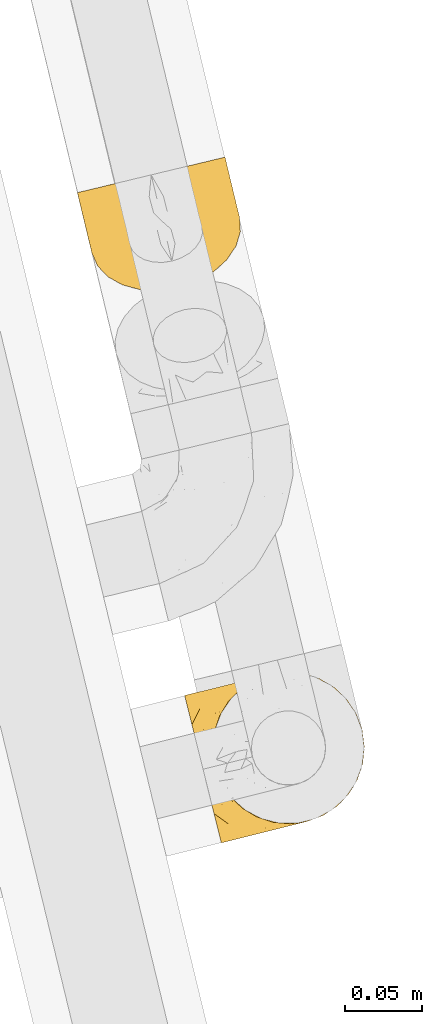
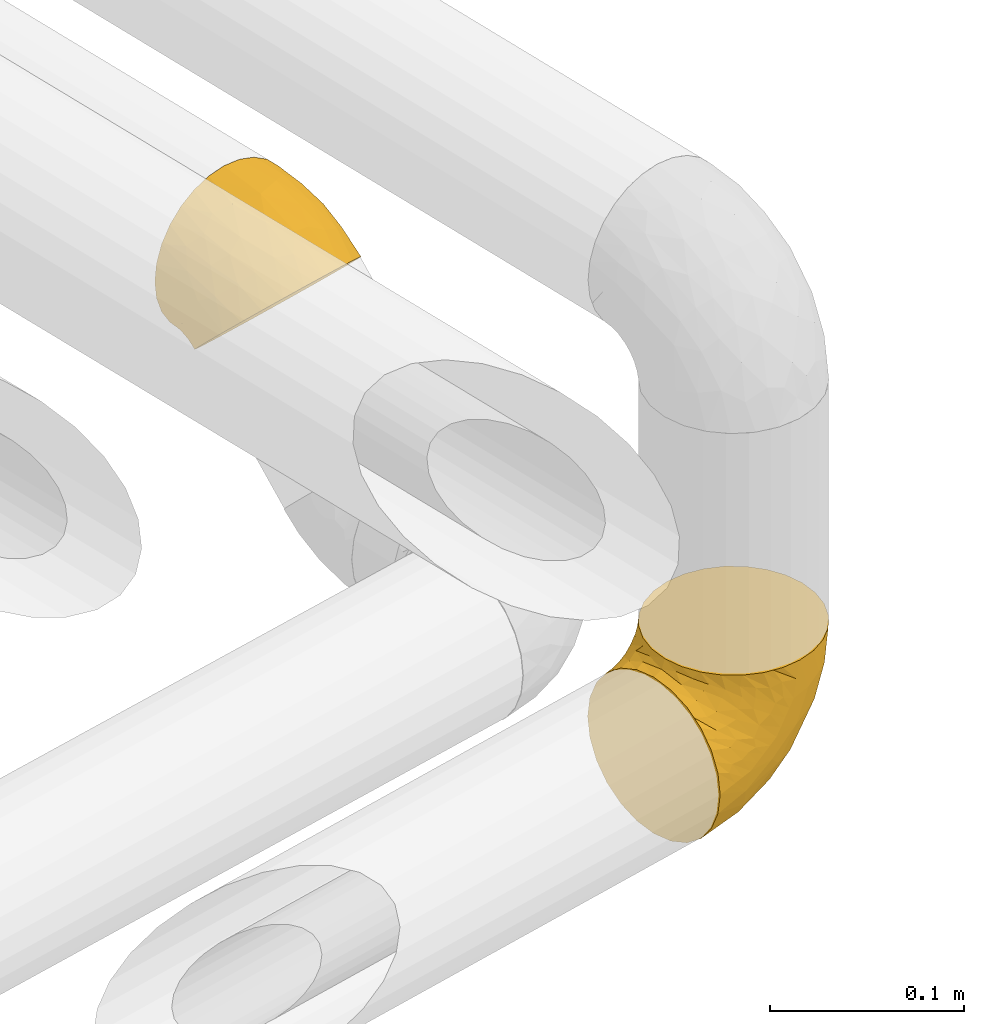
# One storey, part 8 of 93: 2 coverings.
"""IFC2X3 building model written with IfcOpenShell, lengths in millimetres."""

from ifc_helpers import new_model, entity, si_unit, converted_unit, derived_unit, direction, frame, origin, place, context, subcontext, project, spatial, faceted_brep, element, save


model = new_model("IFC2X3")

# Units and contexts
model_context = context("Model", 3, precision=0.01, world=origin(), true_north=direction((6.12303176911189e-17, 1.0)))
body_context = subcontext(model_context, "Body", "Model", "MODEL_VIEW")
ifc_project = project(units=[si_unit("LENGTHUNIT", "METRE", prefix="MILLI"), si_unit("AREAUNIT", "SQUARE_METRE"), si_unit("VOLUMEUNIT", "CUBIC_METRE"), converted_unit("PLANEANGLEUNIT", "DEGREE", entity("IfcRatioMeasure", 0.0174532925199433), si_unit("PLANEANGLEUNIT", "RADIAN"), dimensions=[0, 0, 0, 0, 0, 0, 0]), si_unit("MASSUNIT", "GRAM", prefix="KILO"), derived_unit("MASSDENSITYUNIT", [(si_unit("MASSUNIT", "GRAM", prefix="KILO"), 1), (si_unit("LENGTHUNIT", "METRE"), -3)]), derived_unit("MOMENTOFINERTIAUNIT", [(si_unit("LENGTHUNIT", "METRE"), 4)]), si_unit("TIMEUNIT", "SECOND"), si_unit("FREQUENCYUNIT", "HERTZ"), si_unit("THERMODYNAMICTEMPERATUREUNIT", "DEGREE_CELSIUS"), derived_unit("THERMALTRANSMITTANCEUNIT", [(si_unit("MASSUNIT", "GRAM", prefix="KILO"), 1), (si_unit("THERMODYNAMICTEMPERATUREUNIT", "KELVIN"), -1), (si_unit("TIMEUNIT", "SECOND"), -3)]), derived_unit("VOLUMETRICFLOWRATEUNIT", [(si_unit("LENGTHUNIT", "METRE"), 3), (si_unit("TIMEUNIT", "SECOND"), -1)]), derived_unit("MASSFLOWRATEUNIT", [(si_unit("MASSUNIT", "GRAM", prefix="KILO"), 1), (si_unit("TIMEUNIT", "SECOND"), -1)]), derived_unit("ROTATIONALFREQUENCYUNIT", [(si_unit("TIMEUNIT", "SECOND"), -1)]), si_unit("ELECTRICCURRENTUNIT", "AMPERE"), si_unit("ELECTRICVOLTAGEUNIT", "VOLT"), si_unit("POWERUNIT", "WATT"), si_unit("FORCEUNIT", "NEWTON", prefix="KILO"), si_unit("ILLUMINANCEUNIT", "LUX"), si_unit("LUMINOUSFLUXUNIT", "LUMEN"), si_unit("LUMINOUSINTENSITYUNIT", "CANDELA"), derived_unit("USERDEFINED", [(si_unit("MASSUNIT", "GRAM", prefix="KILO"), -1), (si_unit("LENGTHUNIT", "METRE"), -2), (si_unit("TIMEUNIT", "SECOND"), 3), (si_unit("LUMINOUSFLUXUNIT", "LUMEN"), 1)]), derived_unit("LINEARVELOCITYUNIT", [(si_unit("LENGTHUNIT", "METRE"), 1), (si_unit("TIMEUNIT", "SECOND"), -1)]), si_unit("PRESSUREUNIT", "PASCAL"), derived_unit("USERDEFINED", [(si_unit("LENGTHUNIT", "METRE"), -2), (si_unit("MASSUNIT", "GRAM", prefix="KILO"), 1), (si_unit("TIMEUNIT", "SECOND"), -2)]), derived_unit("LINEARFORCEUNIT", [(si_unit("MASSUNIT", "GRAM", prefix="KILO"), 1), (si_unit("LENGTHUNIT", "METRE"), 1), (si_unit("TIMEUNIT", "SECOND"), -2), (si_unit("LENGTHUNIT", "METRE"), -1)]), derived_unit("PLANARFORCEUNIT", [(si_unit("MASSUNIT", "GRAM", prefix="KILO"), 1), (si_unit("LENGTHUNIT", "METRE"), 1), (si_unit("TIMEUNIT", "SECOND"), -2), (si_unit("LENGTHUNIT", "METRE"), -2)])], contexts=[model_context])

# Site, building, storey
site_placement = place(None, origin())
site = spatial("IfcSite", under=ifc_project, at=site_placement, CompositionType="ELEMENT")
building_placement = place(site_placement, origin())
building = spatial("IfcBuilding", under=site, at=building_placement, CompositionType="ELEMENT")
storey_placement = place(building_placement, frame((0.0, 0.0, -4200.0)))
storey = spatial("IfcBuildingStorey", under=building, at=storey_placement, CompositionType="ELEMENT", Elevation=-4200.0)

# Coverings
covering_1_placement = place(storey_placement, frame((-14701.1, 9970.32, 2339.8)))
element("IfcCovering", 1, at=covering_1_placement, inside=storey, PredefinedType="INSULATION", context=body_context, shape_type="Brep", body=[
    faceted_brep([(2.79, 65.19, 42.11), (1.6, 64.9, 53.04), (2.79, 65.19, 63.99), (6.33, 66.04, 74.38), (12.03, 67.41, 83.7), (19.59, 69.23, 91.48), (28.66, 71.41, 97.33), (38.75, 73.84, 100.96), (49.38, 76.4, 102.19), (60.02, 78.96, 100.96), (70.12, 81.39, 97.32), (79.18, 83.57, 91.47), (86.75, 85.38, 83.68), (92.44, 86.75, 74.36), (95.97, 87.6, 63.98), (97.17, 87.89, 53.04), (95.97, 87.6, 42.1), (92.43, 86.75, 31.71), (86.74, 85.38, 22.39), (79.17, 83.56, 14.61), (70.11, 81.38, 8.76), (60.01, 78.95, 5.13), (49.38, 76.4, 3.89), (38.74, 73.84, 5.13), (28.64, 71.41, 8.77), (19.58, 69.23, 14.62), (12.02, 67.41, 22.41), (6.32, 66.04, 31.73), (11.02, 25.71, 36.35), (10.69, 32.09, 30.07), (10.55, 34.85, 27.35), (11.95, 39.5, 23.16), (13.36, 44.15, 18.97), (19.27, 52.97, 11.77), (27.88, 60.73, 6.25), (38.59, 66.87, 2.78), (50.68, 71.0, 1.6), (63.33, 72.82, 2.78), (75.66, 72.22, 6.25), (86.85, 69.23, 11.77), (96.13, 64.06, 18.97), (102.86, 57.06, 27.35), (103.99, 54.54, 30.07), (106.6, 48.7, 36.35), (107.07, 39.57, 45.34), (104.26, 30.27, 53.73), (98.35, 21.44, 60.92), (89.74, 13.69, 66.45), (79.03, 7.55, 69.92), (66.94, 3.42, 71.1), (54.29, 1.6, 69.92), (41.95, 2.2, 66.45), (30.77, 5.19, 60.92), (21.49, 10.36, 53.73), (14.75, 17.36, 45.34), (21.51, 48.22, 86.45), (61.79, 24.79, 87.97), (55.32, 15.0, 81.93), (33.76, 17.3, 76.36), (45.08, 17.29, 81.87), (34.49, 34.13, 88.36), (25.03, 20.02, 70.88), (49.66, 33.48, 92.55), (17.97, 35.85, 75.33), (26.78, 31.46, 81.72), (9.86, 45.6, 68.4), (15.47, 26.49, 62.14), (9.96, 35.08, 56.16), (5.53, 50.96, 58.8), (6.7, 43.69, 48.71), (29.1, 53.12, 93.64), (39.74, 50.57, 97.16), (55.81, 49.69, 98.58), (13.04, 52.53, 78.98), (7.78, 39.17, 45.6), (8.87, 34.65, 42.49), (9.41, 32.42, 40.95), (9.95, 30.18, 39.42), (2.86, 59.63, 51.97), (4.13, 54.36, 50.89), (5.41, 49.03, 49.8), (32.04, 67.88, 6.86), (7.84, 47.63, 35.0), (9.21, 41.05, 31.94), (6.06, 50.79, 40.6), (8.2, 53.48, 32.05), (21.07, 62.53, 13.41), (16.86, 55.8, 16.6), (11.88, 55.69, 24.2), (9.62, 37.06, 31.56), (3.72, 59.93, 43.37), (4.79, 55.27, 42.87), (41.28, 70.82, 4.01), (12.22, 49.13, 23.01), (13.67, 62.54, 21.32), (7.17, 57.64, 33.36), (50.08, 73.48, 3.3), (87.71, 72.85, 16.6), (80.88, 76.92, 13.4), (94.88, 69.01, 23.01), (59.14, 75.11, 4.01), (68.69, 76.7, 6.85), (98.44, 82.62, 51.97), (92.18, 75.02, 24.17), (105.52, 53.17, 39.42), (103.38, 58.69, 33.9), (87.48, 80.3, 21.3), (101.23, 63.19, 31.94), (102.27, 66.68, 48.71), (99.46, 69.68, 34.99), (99.61, 73.29, 40.59), (103.36, 62.16, 45.6), (95.5, 78.89, 33.34), (99.7, 77.35, 50.89), (97.54, 82.5, 43.38), (98.7, 77.87, 42.85), (96.47, 74.71, 32.03), (100.99, 72.02, 49.8), (104.45, 57.64, 42.49), (98.59, 66.95, 68.39), (103.28, 57.54, 56.15), (87.03, 63.98, 86.44), (102.29, 47.37, 62.12), (95.81, 54.58, 75.32), (70.95, 26.63, 86.73), (80.1, 25.72, 81.87), (90.17, 30.86, 76.36), (81.88, 45.54, 88.35), (100.01, 73.68, 58.8), (96.71, 37.27, 70.88), (92.61, 71.67, 78.97), (73.76, 40.2, 91.37), (69.73, 57.78, 97.16), (78.04, 64.89, 93.63), (89.94, 46.65, 81.72)], [[[0, 1, 2, 3, 4, 5, 6, 7, 8, 9, 10, 11, 12, 13, 14, 15, 16, 17, 18, 19, 20, 21, 22, 23, 24, 25, 26, 27]], [[28, 29, 30, 31, 32, 33, 34, 35, 36, 37, 38, 39, 40, 41, 42, 43, 44, 45, 46, 47, 48, 49, 50, 51, 52, 53, 54]], [[4, 55, 5]], [[49, 56, 57]], [[51, 58, 52]], [[59, 60, 58]], [[61, 53, 52]], [[60, 59, 62]], [[63, 61, 64]], [[63, 65, 66]], [[67, 28, 54]], [[66, 67, 54]], [[51, 50, 59]], [[67, 68, 69]], [[58, 61, 52]], [[70, 60, 71]], [[71, 62, 72]], [[72, 7, 71]], [[55, 70, 5]], [[6, 70, 71]], [[59, 58, 51]], [[8, 7, 72]], [[73, 55, 4]], [[67, 69, 74, 75, 76, 77, 28]], [[50, 57, 59]], [[68, 1, 78, 79, 80, 69]], [[3, 2, 65]], [[73, 65, 63]], [[54, 53, 66]], [[67, 66, 65]], [[3, 73, 4]], [[57, 62, 59]], [[68, 65, 2]], [[6, 71, 7]], [[60, 55, 64]], [[66, 53, 61]], [[64, 61, 58]], [[61, 63, 66]], [[60, 64, 58]], [[63, 64, 55]], [[65, 73, 3]], [[55, 73, 63]], [[65, 68, 67]], [[1, 68, 2]], [[5, 70, 6]], [[55, 60, 70]], [[49, 57, 50]], [[62, 57, 56]], [[72, 62, 56]], [[62, 71, 60]], [[34, 81, 35]], [[82, 83, 74]], [[84, 85, 82]], [[86, 87, 88]], [[77, 89, 30]], [[87, 34, 33]], [[90, 27, 91]], [[92, 23, 22]], [[86, 24, 81]], [[36, 35, 92]], [[34, 86, 81]], [[93, 33, 32]], [[87, 33, 93]], [[83, 93, 32]], [[94, 95, 26]], [[27, 26, 95]], [[27, 95, 91]], [[1, 0, 78]], [[94, 88, 85]], [[86, 94, 25]], [[30, 29, 28, 77]], [[96, 92, 22]], [[80, 91, 84]], [[24, 23, 81]], [[25, 24, 86]], [[90, 78, 0]], [[23, 92, 81]], [[94, 86, 88]], [[82, 93, 83]], [[25, 94, 26]], [[80, 84, 69]], [[82, 88, 93]], [[31, 30, 89]], [[69, 82, 74]], [[83, 75, 74]], [[88, 87, 93]], [[34, 87, 86]], [[91, 80, 79]], [[91, 79, 90]], [[84, 91, 95]], [[85, 84, 95]], [[69, 84, 82]], [[78, 90, 79]], [[27, 90, 0]], [[94, 85, 95]], [[82, 85, 88]], [[36, 92, 96]], [[81, 92, 35]], [[83, 89, 75]], [[77, 76, 75, 89]], [[83, 31, 89]], [[83, 32, 31]], [[97, 38, 98]], [[39, 99, 40]], [[100, 101, 37]], [[16, 15, 102]], [[103, 99, 97]], [[101, 38, 37]], [[104, 42, 105]], [[98, 106, 103]], [[107, 40, 99]], [[97, 99, 39]], [[108, 109, 110]], [[20, 98, 101]], [[36, 96, 100]], [[109, 111, 107]], [[22, 21, 100]], [[112, 106, 18]], [[101, 21, 20]], [[102, 113, 114]], [[105, 40, 107]], [[19, 98, 20]], [[18, 106, 19]], [[112, 18, 17]], [[106, 98, 19]], [[17, 16, 114]], [[112, 115, 110]], [[113, 115, 114]], [[38, 101, 98]], [[112, 116, 106]], [[38, 97, 39]], [[96, 22, 100]], [[115, 113, 117]], [[103, 109, 99]], [[109, 107, 99]], [[105, 107, 118]], [[111, 109, 108]], [[111, 118, 107]], [[103, 97, 98]], [[110, 116, 112]], [[110, 115, 117]], [[17, 115, 112]], [[108, 110, 117]], [[116, 109, 103]], [[17, 114, 115]], [[102, 114, 16]], [[109, 116, 110]], [[106, 116, 103]], [[104, 43, 42]], [[42, 41, 105]], [[101, 100, 21]], [[36, 100, 37]], [[104, 105, 118]], [[40, 105, 41]], [[14, 13, 119]], [[44, 43, 120]], [[120, 43, 104, 118, 111, 108]], [[121, 12, 11]], [[45, 44, 122]], [[122, 119, 123]], [[48, 124, 49]], [[125, 126, 127]], [[125, 48, 47]], [[128, 120, 108]], [[129, 45, 122]], [[47, 126, 125]], [[129, 126, 46]], [[46, 126, 47]], [[120, 128, 119]], [[44, 120, 122]], [[119, 13, 130]], [[131, 127, 132]], [[130, 13, 12]], [[133, 11, 10]], [[134, 127, 126]], [[123, 130, 121]], [[125, 127, 131]], [[10, 132, 133]], [[9, 8, 72]], [[72, 56, 124]], [[9, 72, 132]], [[133, 132, 127]], [[123, 129, 122]], [[9, 132, 10]], [[119, 122, 120]], [[128, 15, 14]], [[48, 125, 124]], [[126, 129, 134]], [[45, 129, 46]], [[134, 123, 121]], [[123, 134, 129]], [[127, 134, 121]], [[121, 130, 12]], [[119, 130, 123]], [[128, 108, 117, 113, 102, 15]], [[119, 128, 14]], [[127, 121, 133]], [[11, 133, 121]], [[72, 131, 132]], [[124, 125, 131]], [[72, 124, 131]], [[124, 56, 49]]]),
])
covering_2_placement = place(storey_placement, frame((-14631.67, 9612.73, 2242.1)))
element("IfcCovering", 2, at=covering_2_placement, inside=storey, PredefinedType="INSULATION", context=body_context, shape_type="Brep", body=[
    faceted_brep([(80.68, 15.38, 107.75), (91.0, 19.23, 107.75), (100.2, 25.27, 107.75), (107.83, 33.21, 107.75), (113.5, 42.65, 107.75), (116.92, 53.1, 107.75), (117.93, 64.06, 107.75), (116.48, 74.97, 107.75), (112.64, 85.28, 107.75), (106.6, 94.49, 107.75), (98.66, 102.11, 107.75), (89.22, 107.78, 107.75), (78.76, 111.2, 107.75), (67.81, 112.21, 107.75), (56.9, 110.76, 107.75), (51.53, 108.76, 107.75), (46.58, 106.92, 107.75), (41.98, 103.9, 107.75), (37.38, 100.88, 107.75), (29.76, 92.94, 107.75), (24.09, 83.5, 107.75), (20.66, 73.05, 107.75), (19.65, 62.09, 107.75), (21.1, 51.18, 107.75), (24.95, 40.87, 107.75), (30.99, 31.66, 107.75), (38.93, 24.04, 107.75), (48.36, 18.37, 107.75), (58.82, 14.95, 107.75), (64.3, 14.44, 107.75), (69.78, 13.93, 107.75), (75.0, 14.63, 107.75), (77.84, 15.01, 107.75), (10.41, 61.63, 98.22), (7.54, 73.13, 93.31), (6.31, 78.07, 89.4), (5.08, 83.01, 85.5), (4.13, 86.8, 80.41), (3.19, 90.59, 75.32), (2.59, 92.97, 69.39), (2.0, 95.35, 63.47), (1.78, 96.24, 56.48), (1.69, 96.61, 53.61), (1.6, 96.98, 50.75), (2.0, 95.35, 38.02), (3.19, 90.59, 26.17), (5.08, 83.01, 15.99), (7.54, 73.13, 8.18), (10.41, 61.63, 3.27), (13.49, 49.29, 1.6), (16.56, 36.94, 3.27), (19.43, 25.44, 8.18), (21.89, 15.56, 15.99), (23.78, 7.98, 26.17), (24.97, 3.22, 38.02), (25.38, 1.6, 50.75), (25.19, 2.33, 56.48), (24.97, 3.22, 63.47), (24.38, 5.6, 69.39), (23.78, 7.98, 75.32), (22.84, 11.77, 80.41), (21.89, 15.56, 85.5), (20.66, 20.5, 89.4), (19.43, 25.44, 93.31), (16.56, 36.94, 98.22), (13.49, 49.29, 99.9), (81.89, 57.52, 27.53), (75.16, 41.65, 25.32), (65.49, 48.88, 16.29), (45.31, 57.22, 6.79), (36.53, 46.89, 4.51), (25.21, 52.21, 3.51), (58.52, 33.73, 17.47), (41.51, 38.82, 7.6), (38.34, 26.44, 12.27), (92.66, 24.13, 70.89), (87.47, 18.25, 87.17), (79.31, 16.59, 67.3), (45.6, 12.13, 31.65), (66.53, 22.15, 33.58), (68.15, 15.94, 47.23), (44.1, 7.41, 43.26), (46.54, 6.87, 55.08), (41.22, 5.54, 53.99), (35.89, 4.22, 52.9), (33.26, 3.56, 52.36), (30.63, 2.91, 51.82), (46.76, 19.89, 21.5), (97.1, 23.9, 89.94), (106.99, 62.62, 60.45), (114.97, 59.65, 83.0), (107.42, 49.91, 64.79), (76.47, 14.34, 85.93), (73.48, 13.59, 81.31), (70.48, 12.84, 76.69), (67.48, 12.09, 72.06), (64.48, 11.35, 67.44), (104.22, 30.79, 88.74), (98.35, 57.67, 45.98), (79.7, 23.39, 47.13), (114.41, 49.19, 89.4), (114.63, 74.5, 95.66), (71.54, 31.36, 28.5), (85.25, 31.79, 42.81), (87.71, 40.81, 38.28), (96.81, 70.06, 45.35), (85.42, 67.22, 33.61), (109.24, 39.9, 82.57), (80.16, 15.25, 105.04), (79.64, 15.12, 102.33), (78.59, 14.86, 96.91), (77.53, 14.6, 91.42), (99.65, 33.27, 65.92), (97.19, 39.13, 53.11), (61.92, 11.46, 54.37), (111.44, 73.71, 74.94), (60.0, 10.23, 64.35), (55.51, 9.11, 61.26), (51.03, 7.99, 58.17), (74.03, 64.38, 21.87), (88.35, 50.57, 34.79), (98.28, 48.26, 48.48), (104.13, 71.88, 60.15), (59.67, 60.8, 14.33), (69.1, 13.74, 99.07), (32.13, 4.19, 60.55), (41.3, 6.7, 64.18), (34.77, 5.59, 64.36), (27.67, 34.52, 103.17), (33.47, 27.39, 101.69), (64.73, 12.81, 87.75), (69.68, 13.26, 89.38), (27.58, 18.97, 88.34), (30.3, 13.57, 82.14), (25.73, 26.55, 94.51), (33.19, 19.04, 89.64), (30.67, 27.66, 98.41), (22.48, 37.07, 99.71), (44.4, 15.68, 89.37), (52.1, 13.7, 88.21), (47.27, 16.87, 95.2), (28.28, 11.3, 79.14), (35.15, 8.51, 72.69), (46.78, 18.53, 101.22), (40.16, 21.55, 99.41), (41.92, 14.12, 84.72), (62.16, 13.89, 97.47), (18.87, 50.63, 102.19), (22.94, 43.16, 104.02), (61.09, 12.07, 82.66), (37.69, 21.13, 95.42), (54.09, 11.2, 78.67), (45.83, 7.87, 66.46), (39.73, 9.96, 75.3), (50.19, 9.69, 72.74), (36.37, 13.86, 82.93), (54.55, 15.45, 99.27), (53.91, 14.62, 93.51), (50.7, 8.73, 67.35), (13.62, 75.1, 94.51), (17.05, 91.3, 82.94), (11.69, 82.67, 88.33), (16.67, 85.22, 89.64), (19.75, 71.77, 103.62), (41.6, 105.55, 87.74), (46.19, 107.48, 89.38), (49.69, 108.97, 81.31), (39.83, 103.38, 97.47), (24.01, 86.28, 99.41), (4.22, 97.63, 51.28), (12.11, 99.6, 52.9), (6.85, 98.29, 51.82), (28.42, 92.05, 101.21), (28.09, 93.76, 95.19), (11.77, 97.86, 64.36), (13.47, 95.46, 72.69), (11.56, 88.72, 82.13), (18.19, 96.33, 75.3), (8.71, 89.77, 79.14), (33.82, 98.41, 99.28), (32.89, 98.86, 93.51), (8.77, 97.86, 60.55), (22.6, 101.04, 66.46), (18.23, 100.05, 63.96), (54.81, 110.24, 96.91), (45.9, 106.78, 99.06), (15.68, 64.3, 99.7), (17.44, 100.92, 53.99), (22.76, 102.25, 55.08), (18.55, 63.08, 103.3), (55.86, 110.5, 102.33), (55.33, 110.37, 99.62), (46.7, 108.22, 76.69), (38.04, 104.49, 82.66), (21.63, 85.49, 95.42), (43.7, 107.47, 72.06), (31.42, 101.95, 78.68), (30.87, 98.84, 88.2), (27.31, 101.47, 72.75), (22.06, 93.66, 84.74), (53.75, 109.98, 91.42), (52.69, 109.72, 85.93), (18.5, 76.43, 98.41), (24.99, 93.46, 89.37), (27.31, 102.57, 67.35), (31.73, 104.49, 61.26), (27.25, 103.37, 58.17), (36.22, 105.61, 64.35), (40.7, 106.73, 67.44), (38.8, 105.42, 54.08), (32.71, 62.22, 4.51), (29.07, 90.86, 21.5), (47.27, 98.1, 33.43), (56.27, 92.39, 28.5), (45.95, 84.17, 17.47), (64.37, 85.03, 25.36), (75.61, 110.94, 90.18), (64.48, 111.42, 86.97), (20.86, 100.63, 43.26), (59.21, 74.05, 16.29), (33.32, 71.69, 7.6), (24.71, 81.12, 12.27), (24.39, 97.17, 31.65), (96.7, 92.85, 64.79), (107.95, 87.79, 83.0), (102.29, 81.42, 60.44), (75.1, 91.64, 38.35), (80.19, 83.3, 34.8), (71.74, 108.78, 71.54), (92.34, 81.69, 45.94), (77.75, 74.13, 27.53), (93.61, 102.54, 82.57), (84.9, 108.22, 88.74), (82.73, 97.53, 53.19), (87.91, 89.97, 48.49), (56.28, 109.06, 67.28), (63.67, 104.64, 52.32), (102.54, 96.76, 89.4), (81.95, 103.87, 65.75), (46.65, 104.23, 46.73), (68.63, 98.44, 42.82)], [[[0, 1, 2, 3, 4, 5, 6, 7, 8, 9, 10, 11, 12, 13, 14, 15, 16, 17, 18, 19, 20, 21, 22, 23, 24, 25, 26, 27, 28, 29, 30, 31, 32]], [[33, 34, 35, 36, 37, 38, 39, 40, 41, 42, 43, 44, 45, 46, 47, 48, 49, 50, 51, 52, 53, 54, 55, 56, 57, 58, 59, 60, 61, 62, 63, 64, 65]], [[66, 67, 68]], [[69, 70, 71]], [[68, 72, 73]], [[73, 72, 74]], [[75, 76, 77]], [[78, 79, 80]], [[51, 50, 73]], [[81, 82, 83, 84, 85, 86, 55]], [[52, 87, 53]], [[74, 52, 51]], [[2, 1, 88]], [[89, 90, 91]], [[77, 92, 93, 94, 95, 96]], [[55, 54, 81]], [[78, 53, 87]], [[5, 90, 6]], [[88, 76, 75]], [[97, 3, 2]], [[89, 91, 98]], [[99, 80, 79]], [[90, 5, 100]], [[74, 87, 52]], [[100, 5, 4]], [[90, 101, 6]], [[79, 102, 103]], [[102, 67, 104]], [[105, 98, 106]], [[107, 4, 3]], [[76, 0, 108, 109, 110, 111, 92]], [[107, 112, 113]], [[114, 77, 96]], [[89, 115, 90]], [[114, 96, 116, 117, 118, 82]], [[75, 97, 88]], [[119, 66, 68]], [[50, 71, 70]], [[100, 91, 90]], [[99, 77, 80]], [[102, 104, 103]], [[97, 107, 3]], [[80, 81, 78]], [[107, 97, 112]], [[68, 73, 70]], [[66, 98, 120]], [[78, 81, 54]], [[114, 81, 80]], [[53, 78, 54]], [[78, 87, 79]], [[102, 87, 72]], [[79, 103, 99]], [[4, 107, 100]], [[91, 100, 107]], [[88, 97, 2]], [[112, 97, 75]], [[99, 112, 75]], [[103, 104, 113]], [[91, 121, 98]], [[89, 105, 122, 115]], [[101, 90, 115]], [[101, 7, 6]], [[88, 1, 76]], [[0, 76, 1]], [[92, 77, 76]], [[73, 74, 51]], [[87, 74, 72]], [[81, 114, 82]], [[77, 114, 80]], [[87, 102, 79]], [[67, 102, 72]], [[68, 67, 72]], [[67, 120, 104]], [[120, 121, 104]], [[104, 121, 113]], [[121, 120, 98]], [[91, 107, 113]], [[91, 113, 121]], [[103, 113, 112]], [[106, 98, 66]], [[105, 89, 98]], [[106, 66, 119]], [[67, 66, 120]], [[68, 69, 123, 119]], [[50, 49, 71]], [[50, 70, 73]], [[112, 99, 103]], [[77, 99, 75]], [[69, 68, 70]], [[29, 124, 110]], [[84, 83, 125]], [[126, 82, 118]], [[59, 58, 127]], [[25, 128, 129]], [[130, 93, 131]], [[132, 62, 133]], [[134, 135, 136]], [[137, 65, 64]], [[64, 134, 137]], [[138, 139, 140]], [[111, 110, 124, 92]], [[134, 136, 137]], [[134, 64, 63]], [[141, 60, 142]], [[125, 58, 57]], [[143, 144, 140]], [[143, 26, 144]], [[127, 83, 82]], [[28, 124, 29]], [[108, 0, 32, 31, 30, 110, 109]], [[30, 29, 110]], [[135, 145, 138]], [[28, 146, 124]], [[57, 56, 55, 86, 85, 84]], [[147, 148, 23]], [[24, 23, 148]], [[25, 144, 26]], [[95, 94, 149]], [[24, 128, 25]], [[150, 138, 144]], [[124, 146, 131]], [[127, 58, 125]], [[151, 149, 139]], [[127, 126, 142]], [[142, 59, 127]], [[152, 142, 126]], [[153, 154, 155]], [[153, 133, 141]], [[146, 28, 27]], [[143, 156, 27]], [[157, 149, 130]], [[61, 133, 62]], [[134, 132, 135]], [[148, 128, 24]], [[65, 137, 147]], [[147, 137, 148]], [[128, 137, 136]], [[137, 128, 148]], [[128, 136, 129]], [[150, 129, 136]], [[25, 129, 144]], [[158, 152, 117]], [[152, 118, 117]], [[153, 142, 152]], [[158, 116, 154]], [[145, 151, 138]], [[153, 152, 158]], [[133, 153, 155]], [[133, 155, 132]], [[153, 141, 142]], [[135, 132, 155]], [[134, 63, 132]], [[145, 135, 155]], [[135, 138, 150]], [[155, 154, 145]], [[151, 154, 96]], [[154, 151, 145]], [[149, 94, 130]], [[82, 126, 127]], [[118, 152, 126]], [[151, 96, 95]], [[139, 149, 157]], [[151, 95, 149]], [[93, 92, 131]], [[130, 146, 156]], [[130, 94, 93]], [[84, 125, 57]], [[127, 125, 83]], [[140, 139, 157]], [[151, 139, 138]], [[140, 157, 143]], [[138, 140, 144]], [[156, 143, 157]], [[27, 26, 143]], [[130, 156, 157]], [[146, 27, 156]], [[132, 63, 62]], [[124, 131, 92]], [[130, 131, 146]], [[129, 150, 144]], [[135, 150, 136]], [[60, 141, 61]], [[60, 59, 142]], [[133, 61, 141]], [[116, 96, 154]], [[153, 158, 154]], [[158, 117, 116]], [[34, 33, 159]], [[160, 161, 162]], [[22, 21, 163]], [[164, 165, 166]], [[19, 18, 167]], [[168, 21, 20]], [[169, 43, 42, 41, 40, 170, 171]], [[172, 173, 168]], [[174, 38, 175]], [[176, 177, 178]], [[179, 164, 180]], [[40, 181, 170]], [[182, 183, 175]], [[17, 184, 185]], [[65, 147, 186]], [[187, 174, 188]], [[23, 22, 189]], [[174, 39, 38]], [[15, 14, 190, 191, 184, 16]], [[181, 40, 39]], [[192, 193, 164]], [[194, 163, 168]], [[33, 186, 159]], [[180, 173, 172]], [[195, 196, 193]], [[18, 185, 167]], [[173, 180, 197]], [[198, 199, 196]], [[200, 201, 185, 184]], [[184, 17, 16]], [[18, 17, 185]], [[202, 159, 186]], [[194, 168, 203]], [[189, 163, 202]], [[204, 205, 182]], [[187, 181, 174]], [[160, 177, 176]], [[206, 183, 182]], [[206, 182, 205]], [[201, 165, 185]], [[165, 164, 167]], [[172, 179, 180]], [[202, 194, 162]], [[176, 161, 160]], [[65, 186, 33]], [[163, 189, 22]], [[175, 177, 182]], [[174, 183, 188]], [[177, 198, 204]], [[199, 160, 162]], [[198, 207, 204]], [[175, 38, 37]], [[198, 177, 160]], [[178, 177, 175]], [[176, 35, 161]], [[34, 159, 161]], [[162, 161, 159]], [[202, 162, 159]], [[199, 162, 203]], [[196, 199, 203]], [[198, 160, 199]], [[193, 197, 180]], [[208, 198, 196]], [[188, 183, 206]], [[175, 183, 174]], [[193, 192, 195]], [[195, 208, 196]], [[197, 196, 203]], [[180, 164, 193]], [[168, 163, 21]], [[166, 165, 201]], [[166, 192, 164]], [[189, 202, 186]], [[186, 147, 189]], [[23, 189, 147]], [[174, 181, 39]], [[170, 181, 187]], [[196, 197, 193]], [[173, 203, 168]], [[203, 173, 197]], [[172, 168, 20]], [[20, 19, 172]], [[179, 172, 19]], [[19, 167, 179]], [[164, 179, 167]], [[35, 176, 36]], [[35, 34, 161]], [[185, 165, 167]], [[162, 194, 203]], [[163, 194, 202]], [[176, 178, 36]], [[37, 36, 178]], [[175, 37, 178]], [[177, 204, 182]], [[207, 198, 208]], [[207, 205, 204]], [[209, 188, 206, 205, 207, 208]], [[48, 210, 71]], [[211, 212, 213]], [[214, 213, 215]], [[216, 217, 13]], [[218, 43, 169, 171, 170, 187, 188]], [[219, 220, 214]], [[47, 46, 221]], [[210, 48, 220]], [[211, 222, 212]], [[222, 45, 44]], [[221, 220, 47]], [[47, 220, 48]], [[221, 211, 214]], [[223, 224, 225]], [[211, 46, 45]], [[226, 227, 215]], [[43, 218, 44]], [[217, 216, 228]], [[227, 229, 230]], [[14, 13, 217]], [[224, 9, 8]], [[10, 231, 11]], [[11, 232, 12]], [[233, 223, 234]], [[235, 208, 195, 192, 166, 201]], [[236, 235, 228]], [[222, 44, 218]], [[106, 230, 229]], [[224, 237, 9]], [[232, 238, 228]], [[9, 237, 10]], [[115, 224, 101]], [[239, 235, 236]], [[232, 11, 231]], [[223, 231, 237]], [[224, 8, 101]], [[223, 229, 234]], [[225, 115, 122, 105]], [[216, 12, 232]], [[209, 235, 239]], [[210, 219, 69]], [[219, 214, 215]], [[230, 119, 219]], [[209, 218, 188]], [[239, 212, 222]], [[239, 222, 218]], [[45, 222, 211]], [[236, 212, 239]], [[213, 212, 240]], [[223, 237, 224]], [[231, 10, 237]], [[238, 232, 231]], [[216, 232, 228]], [[233, 231, 223]], [[236, 238, 240]], [[115, 225, 224]], [[234, 229, 227]], [[8, 7, 101]], [[235, 209, 208]], [[218, 209, 239]], [[217, 228, 235]], [[13, 12, 216]], [[235, 201, 217]], [[217, 201, 200, 184, 191, 190, 14]], [[211, 221, 46]], [[220, 221, 214]], [[71, 210, 69]], [[71, 49, 48]], [[219, 210, 220]], [[226, 215, 213]], [[211, 213, 214]], [[226, 213, 240]], [[215, 227, 230]], [[233, 240, 238]], [[234, 227, 226]], [[233, 234, 226]], [[229, 223, 225]], [[240, 233, 226]], [[233, 238, 231]], [[225, 105, 229]], [[229, 105, 106]], [[106, 119, 230]], [[123, 69, 219, 119]], [[215, 230, 219]], [[238, 236, 228]], [[212, 236, 240]]]),
])

save(model, "model.ifc")
